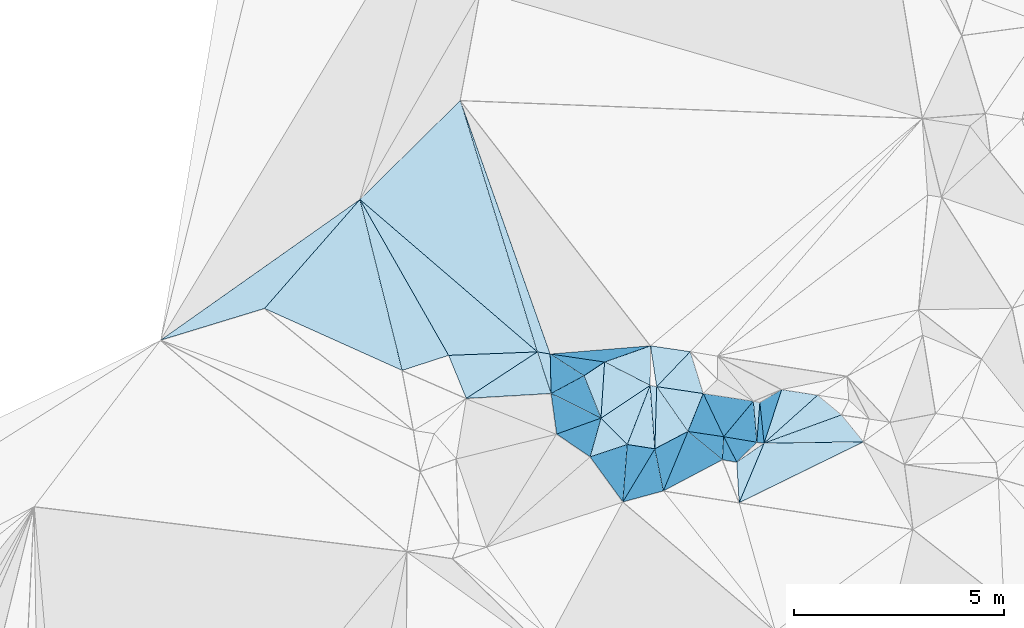
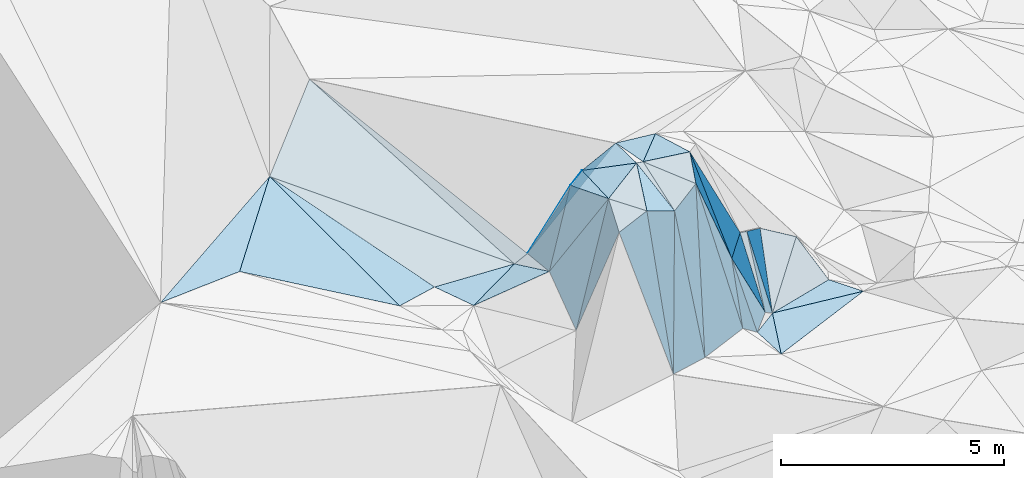
# One storey, part 123 of 275: 45 plates.
"""IFC2X3 building model written with IfcOpenShell, lengths in millimetres."""

from ifc_helpers import new_model, si_unit, frame, origin_with_axes, place, context, subcontext, project, spatial, polyline, outline, extrude, material, type_object, element, save


model = new_model("IFC2X3")

# Units and contexts
model_context = context("Model", 3, precision=1e-05, world=origin_with_axes())
body_context = subcontext(model_context, "Body", "Model", "MODEL_VIEW")
ifc_project = project(units=[si_unit("LENGTHUNIT", "METRE", prefix="MILLI"), si_unit("AREAUNIT", "SQUARE_METRE"), si_unit("VOLUMEUNIT", "CUBIC_METRE"), si_unit("MASSUNIT", "GRAM", prefix="KILO"), si_unit("TIMEUNIT", "SECOND"), si_unit("PLANEANGLEUNIT", "RADIAN"), si_unit("SOLIDANGLEUNIT", "STERADIAN"), si_unit("THERMODYNAMICTEMPERATUREUNIT", "DEGREE_CELSIUS"), si_unit("LUMINOUSINTENSITYUNIT", "LUMEN")], contexts=[model_context])

# Site, building, storey
site_placement = place(None, origin_with_axes())
site = spatial("IfcSite", under=ifc_project, at=site_placement, CompositionType="ELEMENT")
building_placement = place(site_placement, origin_with_axes())
building = spatial("IfcBuilding", under=site, at=building_placement, Name="Undefined", CompositionType="ELEMENT")
storey_placement = place(building_placement, origin_with_axes())
storey = spatial("IfcBuildingStorey", under=building, at=storey_placement, Name="Undefined", CompositionType="ELEMENT", Elevation=0.0)

# Plates
ifc_material = material()
plate_type_1 = type_object("IfcPlateType", PredefinedType="NOTDEFINED")
plate_1_placement = place(storey_placement, frame((-127172.939576721, 114067.120854425, 57145.5302917681), z_axis=(-0.0840497582433798, 0.33247181968247, -0.939360488447463), x_axis=(0.726799203152636, -0.624452343737679, -0.286045780771561)))
element("IfcPlate", 1, at=plate_1_placement, inside=storey, type_object=plate_type_1, material=ifc_material, Name="00", context=body_context, shape_type="SweptSolid", body=[
    extrude(outline(polyline([(0.0, 0.0), (5824.24267578125, -3.29109752783552e-08), (4291.6533203125, 1471.7578125), (0.0, 0.0)])), frame((-8.85201319254618e-08, 2.18876761149539e-07, -0.5000001331573), z_axis=(0.0, 0.0, 1.0), x_axis=(1.0, 0.0, 0.0)), (0.0, 0.0, 1.0), 1.0),
])
plate_type_2 = type_object("IfcPlateType", PredefinedType="NOTDEFINED")
plate_2_placement = place(storey_placement, frame((-121824.827324897, 109861.886820554, 57579.7868933312), z_axis=(0.524908520289815, -0.736789397555767, -0.426160097823067), x_axis=(-0.381293669960746, 0.244086897899004, -0.891648318297021)))
element("IfcPlate", 2, at=plate_2_placement, inside=storey, type_object=plate_type_2, material=ifc_material, Name="00", context=body_context, shape_type="SweptSolid", body=[
    extrude(outline(polyline([(0.0, 0.0), (2119.66967773438, -5.1804818212986e-09), (-142.946792602539, 572.333984375), (0.0, 0.0)])), frame((-8.85201319254618e-08, 2.18876761149539e-07, -0.5000001331573), z_axis=(0.0, 0.0, 1.0), x_axis=(1.0, 0.0, 0.0)), (0.0, 0.0, 1.0), 1.0),
])
plate_type_3 = type_object("IfcPlateType", PredefinedType="NOTDEFINED")
plate_3_placement = place(storey_placement, frame((-122939.799774544, 110429.87060153, 55479.5170197872), z_axis=(0.0858936731765158, -0.244234675615921, -0.965904601984602), x_axis=(0.304212956007485, -0.91675838155648, 0.258860092024883)))
element("IfcPlate", 3, at=plate_3_placement, inside=storey, type_object=plate_type_3, material=ifc_material, Name="00", context=body_context, shape_type="SweptSolid", body=[
    extrude(outline(polyline([(0.0, 0.0), (1081.66540527344, -5.55883161723614e-09), (535.840393066406, 1959.25366210938), (0.0, 0.0)])), frame((-8.85201319254618e-08, 2.18876761149539e-07, -0.5000001331573), z_axis=(0.0, 0.0, 1.0), x_axis=(1.0, 0.0, 0.0)), (0.0, 0.0, 1.0), 1.0),
])
plate_type_4 = type_object("IfcPlateType", PredefinedType="NOTDEFINED")
plate_4_placement = place(storey_placement, frame((-117628.94051765, 109224.930520439, 55239.748582044), z_axis=(-0.0955383613260022, 0.859116325632494, -0.502783810943496), x_axis=(0.0523056062937232, -0.500063738080834, -0.864407532016507)))
element("IfcPlate", 4, at=plate_4_placement, inside=storey, type_object=plate_type_4, material=ifc_material, Name="00", context=body_context, shape_type="SweptSolid", body=[
    extrude(outline(polyline([(0.0, 0.0), (1943.52770996094, -7.40692485123873e-09), (1863.10693359375, 170.389251708984), (0.0, 0.0)])), frame((-8.85201319254618e-08, 2.18876761149539e-07, -0.5000001331573), z_axis=(0.0, 0.0, 1.0), x_axis=(1.0, 0.0, 0.0)), (0.0, 0.0, 1.0), 1.0),
])
plate_type_5 = type_object("IfcPlateType", PredefinedType="NOTDEFINED")
plate_5_placement = place(storey_placement, frame((-121334.99427368, 110188.205598144, 57619.5041985265), z_axis=(0.115421488089065, -0.0592361526261697, -0.991548767489202), x_axis=(0.882497580006892, -0.452069672772387, 0.1297344682089)))
element("IfcPlate", 5, at=plate_5_placement, inside=storey, type_object=plate_type_5, material=ifc_material, Name="00", context=body_context, shape_type="SweptSolid", body=[
    extrude(outline(polyline([(0.0, 0.0), (1233.28833007813, 8.25821189209819e-09), (538.641296386719, 1230.96118164063), (0.0, 0.0)])), frame((-8.85201319254618e-08, 2.18876761149539e-07, -0.5000001331573), z_axis=(0.0, 0.0, 1.0), x_axis=(1.0, 0.0, 0.0)), (0.0, 0.0, 1.0), 1.0),
])
plate_type_6 = type_object("IfcPlateType", PredefinedType="NOTDEFINED")
plate_6_placement = place(storey_placement, frame((-117527.288152102, 108252.652764839, 53559.5043438252), z_axis=(-0.105598940437367, 0.0790763816793108, -0.991259698383332), x_axis=(0.994398388491212, 0.0129590261855554, -0.104899516711961)))
element("IfcPlate", 6, at=plate_6_placement, inside=storey, type_object=plate_type_6, material=ifc_material, Name="00", context=body_context, shape_type="SweptSolid", body=[
    extrude(outline(polyline([(0.0, 0.0), (2383.23315429688, -1.12486304715276e-08), (-605.605895996094, 1419.06359863281), (0.0, 0.0)])), frame((-8.85201319254618e-08, 2.18876761149539e-07, -0.5000001331573), z_axis=(0.0, 0.0, 1.0), x_axis=(1.0, 0.0, 0.0)), (0.0, 0.0, 1.0), 1.0),
])
plate_type_7 = type_object("IfcPlateType", PredefinedType="NOTDEFINED")
plate_7_placement = place(storey_placement, frame((-120246.61358742, 109630.686629709, 57779.5044175174), z_axis=(0.128944405817825, -0.0327123870062438, -0.991112122791686), x_axis=(-0.882497580034507, 0.452069672719858, -0.129734468204099)))
element("IfcPlate", 7, at=plate_7_placement, inside=storey, type_object=plate_type_7, material=ifc_material, Name="00", context=body_context, shape_type="SweptSolid", body=[
    extrude(outline(polyline([(0.0, 0.0), (1233.28833007813, 8.25821189209819e-09), (422.853271484375, 844.863952636719), (0.0, 0.0)])), frame((-8.85201319254618e-08, 2.18876761149539e-07, -0.5000001331573), z_axis=(0.0, 0.0, 1.0), x_axis=(1.0, 0.0, 0.0)), (0.0, 0.0, 1.0), 1.0),
])
plate_type_8 = type_object("IfcPlateType", PredefinedType="NOTDEFINED")
plate_8_placement = place(storey_placement, frame((-120897.87211962, 106850.39406383, 53919.8217663494), z_axis=(0.0537045561599586, 0.932782810628323, -0.356415556400092), x_axis=(0.027312584689679, 0.355424939972838, 0.934305696634069)))
element("IfcPlate", 8, at=plate_8_placement, inside=storey, type_object=plate_type_8, material=ifc_material, Name="00", context=body_context, shape_type="SweptSolid", body=[
    extrude(outline(polyline([(0.0, 0.0), (3853.12866210938, 1.67638063430786e-08), (3675.71435546875, 663.795288085938), (0.0, 0.0)])), frame((-8.85201319254618e-08, 2.18876761149539e-07, -0.5000001331573), z_axis=(0.0, 0.0, 1.0), x_axis=(1.0, 0.0, 0.0)), (0.0, 0.0, 1.0), 1.0),
])
plate_type_9 = type_object("IfcPlateType", PredefinedType="NOTDEFINED")
plate_9_placement = place(storey_placement, frame((-118980.327690746, 109436.521387115, 57759.8296986031), z_axis=(-0.844897435322132, 0.412521827392873, -0.340549652342399), x_axis=(0.180119604287837, -0.380059422050479, -0.907255071003656)))
element("IfcPlate", 9, at=plate_9_placement, inside=storey, type_object=plate_type_9, material=ifc_material, Name="00", context=body_context, shape_type="SweptSolid", body=[
    extrude(outline(polyline([(0.0, 0.0), (2711.4755859375, -1.08011590782553e-08), (450.529602050781, 886.297424316406), (0.0, 0.0)])), frame((-8.85201319254618e-08, 2.18876761149539e-07, -0.5000001331573), z_axis=(0.0, 0.0, 1.0), x_axis=(1.0, 0.0, 0.0)), (0.0, 0.0, 1.0), 1.0),
])
plate_type_10 = type_object("IfcPlateType", PredefinedType="NOTDEFINED")
plate_10_placement = place(storey_placement, frame((-121679.167779488, 107925.614703113, 57419.8460653225), z_axis=(0.93574440796713, -0.172138843323669, -0.307815889091895), x_axis=(-0.275579687908912, 0.187779193895734, -0.942759147371106)))
element("IfcPlate", 10, at=plate_10_placement, inside=storey, type_object=plate_type_10, material=ifc_material, Name="00", context=body_context, shape_type="SweptSolid", body=[
    extrude(outline(polyline([(0.0, 0.0), (2895.75561523438, -4.08908817917109e-09), (-152.429992675781, 984.563415527344), (0.0, 0.0)])), frame((-8.85201319254618e-08, 2.18876761149539e-07, -0.5000001331573), z_axis=(0.0, 0.0, 1.0), x_axis=(1.0, 0.0, 0.0)), (0.0, 0.0, 1.0), 1.0),
])
plate_type_11 = type_object("IfcPlateType", PredefinedType="NOTDEFINED")
plate_11_placement = place(storey_placement, frame((-119345.170555473, 108531.442127853, 57569.5101914301), z_axis=(0.0121128882629374, 0.200771134037029, -0.979563285181419), x_axis=(-0.564890506441915, 0.80970766923569, 0.158972343861135)))
element("IfcPlate", 11, at=plate_11_placement, inside=storey, type_object=plate_type_11, material=ifc_material, Name="00", context=body_context, shape_type="SweptSolid", body=[
    extrude(outline(polyline([(0.0, 0.0), (1320.98449707031, -3.18686943501234e-09), (556.630310058594, 823.809875488281), (0.0, 0.0)])), frame((-8.85201319254618e-08, 2.18876761149539e-07, -0.5000001331573), z_axis=(0.0, 0.0, 1.0), x_axis=(1.0, 0.0, 0.0)), (0.0, 0.0, 1.0), 1.0),
])
plate_type_12 = type_object("IfcPlateType", PredefinedType="NOTDEFINED")
plate_12_placement = place(storey_placement, frame((-118491.876481331, 108406.080765571, 55299.8078385976), z_axis=(-0.722304831567893, 0.574988767741143, -0.384270278925133), x_axis=(-0.18011960428778, 0.380059422051083, 0.907255071003414)))
element("IfcPlate", 12, at=plate_12_placement, inside=storey, type_object=plate_type_12, material=ifc_material, Name="00", context=body_context, shape_type="SweptSolid", body=[
    extrude(outline(polyline([(0.0, 0.0), (2711.4755859375, -1.08011590782553e-08), (140.624542236328, 1097.28063964844), (0.0, 0.0)])), frame((-8.85201319254618e-08, 2.18876761149539e-07, -0.5000001331573), z_axis=(0.0, 0.0, 1.0), x_axis=(1.0, 0.0, 0.0)), (0.0, 0.0, 1.0), 1.0),
])
plate_type_13 = type_object("IfcPlateType", PredefinedType="NOTDEFINED")
plate_13_placement = place(storey_placement, frame((-118491.827664675, 108406.142124906, 55299.8246190274), z_axis=(-0.624669649436294, 0.697703847341124, -0.350709524362444), x_axis=(0.426849675085208, -0.0709979859672468, -0.901531275590729)))
element("IfcPlate", 13, at=plate_13_placement, inside=storey, type_object=plate_type_13, material=ifc_material, Name="00", context=body_context, shape_type="SweptSolid", body=[
    extrude(outline(polyline([(0.0, 0.0), (1852.40380859375, 2.66300048679113e-09), (1762.6826171875, 674.203308105469), (0.0, 0.0)])), frame((-8.85201319254618e-08, 2.18876761149539e-07, -0.5000001331573), z_axis=(0.0, 0.0, 1.0), x_axis=(1.0, 0.0, 0.0)), (0.0, 0.0, 1.0), 1.0),
])
plate_type_14 = type_object("IfcPlateType", PredefinedType="NOTDEFINED")
plate_14_placement = place(storey_placement, frame((-122610.506540229, 109438.342825378, 55759.5861274751), z_axis=(0.559114686730362, -0.048176092364468, -0.827689453362129), x_axis=(-0.304212956009918, 0.916758381555947, -0.258860092023912)))
element("IfcPlate", 14, at=plate_14_placement, inside=storey, type_object=plate_type_14, material=ifc_material, Name="00", context=body_context, shape_type="SweptSolid", body=[
    extrude(outline(polyline([(0.0, 0.0), (1081.66540527344, -5.55883161723614e-09), (887.89013671875, 321.015808105469), (0.0, 0.0)])), frame((-8.85201319254618e-08, 2.18876761149539e-07, -0.5000001331573), z_axis=(0.0, 0.0, 1.0), x_axis=(1.0, 0.0, 0.0)), (0.0, 0.0, 1.0), 1.0),
])
plate_type_15 = type_object("IfcPlateType", PredefinedType="NOTDEFINED")
plate_15_placement = place(storey_placement, frame((-118179.990980498, 107800.506008044, 53539.8351636943), z_axis=(-0.0271668666170141, 0.943722571189827, -0.32962049387906), x_axis=(-0.865215973139182, 0.142951842845666, 0.480589315790361)))
element("IfcPlate", 15, at=plate_15_placement, inside=storey, type_object=plate_type_15, material=ifc_material, Name="00", context=body_context, shape_type="SweptSolid", body=[
    extrude(outline(polyline([(0.0, 0.0), (395.347961425781, 1.26601662486792e-09), (1201.97912597656, 1454.9384765625), (0.0, 0.0)])), frame((-8.85201319254618e-08, 2.18876761149539e-07, -0.5000001331573), z_axis=(0.0, 0.0, 1.0), x_axis=(1.0, 0.0, 0.0)), (0.0, 0.0, 1.0), 1.0),
])
plate_type_16 = type_object("IfcPlateType", PredefinedType="NOTDEFINED")
plate_16_placement = place(storey_placement, frame((-117700.736257544, 108274.699632797, 53629.7465176876), z_axis=(0.162189568164845, 0.846602149252938, -0.506911574989965), x_axis=(-0.0441872193018238, 0.519429277936636, 0.853370209740531)))
element("IfcPlate", 16, at=plate_16_placement, inside=storey, type_object=plate_type_16, material=ifc_material, Name="00", context=body_context, shape_type="SweptSolid", body=[
    extrude(outline(polyline([(0.0, 0.0), (1886.63720703125, -2.43016984313726e-09), (1864.32238769531, 156.531295776367), (0.0, 0.0)])), frame((-8.85201319254618e-08, 2.18876761149539e-07, -0.5000001331573), z_axis=(0.0, 0.0, 1.0), x_axis=(1.0, 0.0, 0.0)), (0.0, 0.0, 1.0), 1.0),
])
plate_type_17 = type_object("IfcPlateType", PredefinedType="NOTDEFINED")
plate_17_placement = place(storey_placement, frame((-117527.544266772, 108252.945153256, 53559.7892620882), z_axis=(-0.617825198170424, 0.663847842602728, -0.421423855966152), x_axis=(-0.0523056063160503, 0.500063738071532, 0.864407532020538)))
element("IfcPlate", 17, at=plate_17_placement, inside=storey, type_object=plate_type_17, material=ifc_material, Name="00", context=body_context, shape_type="SweptSolid", body=[
    extrude(outline(polyline([(0.0, 0.0), (1943.52770996094, -7.40692485123873e-09), (1827.6044921875, 655.638488769531), (0.0, 0.0)])), frame((-8.85201319254618e-08, 2.18876761149539e-07, -0.5000001331573), z_axis=(0.0, 0.0, 1.0), x_axis=(1.0, 0.0, 0.0)), (0.0, 0.0, 1.0), 1.0),
])
plate_type_18 = type_object("IfcPlateType", PredefinedType="NOTDEFINED")
plate_18_placement = place(storey_placement, frame((-121420.513873093, 108849.30583105, 57689.7821673213), z_axis=(0.851345107254935, 0.292325930784554, -0.435611132254478), x_axis=(-0.507915912830475, 0.251517924810495, -0.823869018104582)))
element("IfcPlate", 18, at=plate_18_placement, inside=storey, type_object=plate_type_18, material=ifc_material, Name="00", context=body_context, shape_type="SweptSolid", body=[
    extrude(outline(polyline([(0.0, 0.0), (2342.60546875, -4.51109372079372e-09), (550.711608886719, 947.901245117188), (0.0, 0.0)])), frame((-8.85201319254618e-08, 2.18876761149539e-07, -0.5000001331573), z_axis=(0.0, 0.0, 1.0), x_axis=(1.0, 0.0, 0.0)), (0.0, 0.0, 1.0), 1.0),
])
plate_type_19 = type_object("IfcPlateType", PredefinedType="NOTDEFINED")
plate_19_placement = place(storey_placement, frame((-120898.029786903, 106850.379979577, 53919.8317329329), z_axis=(-0.261630540679101, 0.904615539903942, -0.336482072551067), x_axis=(-0.208790755328857, 0.287323704111256, 0.934800251147267)))
element("IfcPlate", 19, at=plate_19_placement, inside=storey, type_object=plate_type_19, material=ifc_material, Name="00", context=body_context, shape_type="SweptSolid", body=[
    extrude(outline(polyline([(0.0, 0.0), (3744.11547851563, -9.61881596595049e-09), (3736.79711914063, 939.652282714844), (0.0, 0.0)])), frame((-8.85201319254618e-08, 2.18876761149539e-07, -0.5000001331573), z_axis=(0.0, 0.0, 1.0), x_axis=(1.0, 0.0, 0.0)), (0.0, 0.0, 1.0), 1.0),
])
plate_type_20 = type_object("IfcPlateType", PredefinedType="NOTDEFINED")
plate_20_placement = place(storey_placement, frame((-127173.033219942, 114067.112502623, 57145.5453522989), z_axis=(-0.271195394198383, 0.315783845944614, -0.909248932254535), x_axis=(-0.65741873450322, -0.750746778201665, -0.0646520111365831)))
element("IfcPlate", 20, at=plate_20_placement, inside=storey, type_object=plate_type_20, material=ifc_material, Name="00", context=body_context, shape_type="SweptSolid", body=[
    extrude(outline(polyline([(0.0, 0.0), (3464.70263671875, -2.4476321414113e-08), (5632.046875, 1500.78125), (0.0, 0.0)])), frame((-8.85201319254618e-08, 2.18876761149539e-07, -0.5000001331573), z_axis=(0.0, 0.0, 1.0), x_axis=(1.0, 0.0, 0.0)), (0.0, 0.0, 1.0), 1.0),
])
plate_type_21 = type_object("IfcPlateType", PredefinedType="NOTDEFINED")
plate_21_placement = place(storey_placement, frame((-118122.986745631, 106830.280527921, 53509.5002406356), z_axis=(0.00882652118324734, 0.0314373645567734, -0.999466750139056), x_axis=(-0.0586335262089239, 0.997802247637457, 0.0308672028850613)))
element("IfcPlate", 21, at=plate_21_placement, inside=storey, type_object=plate_type_21, material=ifc_material, Name="00", context=body_context, shape_type="SweptSolid", body=[
    extrude(outline(polyline([(0.0, 0.0), (971.905334472656, 1.26601662486792e-09), (1385.83459472656, 678.205444335938), (0.0, 0.0)])), frame((-8.85201319254618e-08, 2.18876761149539e-07, -0.5000001331573), z_axis=(0.0, 0.0, 1.0), x_axis=(1.0, 0.0, 0.0)), (0.0, 0.0, 1.0), 1.0),
])
plate_type_22 = type_object("IfcPlateType", PredefinedType="NOTDEFINED")
plate_22_placement = place(storey_placement, frame((-120246.651579788, 109630.841197185, 57779.520185483), z_axis=(0.0529566791147433, 0.276424918776054, -0.95957535108859), x_axis=(0.98213927472563, -0.188155374734322, 2.49505239104413e-10)))
element("IfcPlate", 22, at=plate_22_placement, inside=storey, type_object=plate_type_22, material=ifc_material, Name="00", context=body_context, shape_type="SweptSolid", body=[
    extrude(outline(polyline([(0.0, 0.0), (158.113876342773, 6.40284270048141e-10), (394.652252197266, 1527.79235839844), (0.0, 0.0)])), frame((-8.85201319254618e-08, 2.18876761149539e-07, -0.5000001331573), z_axis=(0.0, 0.0, 1.0), x_axis=(1.0, 0.0, 0.0)), (0.0, 0.0, 1.0), 1.0),
])
plate_type_23 = type_object("IfcPlateType", PredefinedType="NOTDEFINED")
plate_23_placement = place(storey_placement, frame((-124635.661299559, 109319.484283303, 55609.5013918202), z_axis=(-0.0752889469623513, -0.00176249610350033, -0.997160201809511), x_axis=(-0.379347486268862, 0.924860038109411, 0.0270073058588546)))
element("IfcPlate", 23, at=plate_23_placement, inside=storey, type_object=plate_type_23, material=ifc_material, Name="00", context=body_context, shape_type="SweptSolid", body=[
    extrude(outline(polyline([(0.0, 0.0), (1110.810546875, 3.49245965480804e-10), (380.262878417969, 1995.29455566406), (0.0, 0.0)])), frame((-8.85201319254618e-08, 2.18876761149539e-07, -0.5000001331573), z_axis=(0.0, 0.0, 1.0), x_axis=(1.0, 0.0, 0.0)), (0.0, 0.0, 1.0), 1.0),
])
plate_type_24 = type_object("IfcPlateType", PredefinedType="NOTDEFINED")
plate_24_placement = place(storey_placement, frame((-127172.982069396, 114067.097475043, 57145.5283278775), z_axis=(-0.169045525666872, 0.2857180981798, -0.943286159457738), x_axis=(0.4663634840826, -0.819952814637612, -0.331937467728782)))
element("IfcPlate", 24, at=plate_24_placement, inside=storey, type_object=plate_type_24, material=ifc_material, Name="00", context=body_context, shape_type="SweptSolid", body=[
    extrude(outline(polyline([(0.0, 0.0), (4536.9990234375, 9.50240064412355e-09), (4284.30810546875, 1142.03637695313), (0.0, 0.0)])), frame((-8.85201319254618e-08, 2.18876761149539e-07, -0.5000001331573), z_axis=(0.0, 0.0, 1.0), x_axis=(1.0, 0.0, 0.0)), (0.0, 0.0, 1.0), 1.0),
])
plate_type_25 = type_object("IfcPlateType", PredefinedType="NOTDEFINED")
plate_25_placement = place(storey_placement, frame((-119931.978891423, 107113.476902548, 53879.8614080152), z_axis=(-0.385092214900645, 0.88028533360275, -0.277131227880963), x_axis=(-0.0561456222692682, 0.277387139984796, 0.959116282663918)))
element("IfcPlate", 25, at=plate_25_placement, inside=storey, type_object=plate_type_25, material=ifc_material, Name="00", context=body_context, shape_type="SweptSolid", body=[
    extrude(outline(polyline([(0.0, 0.0), (3617.91381835938, 2.7648638933897e-09), (3899.623046875, 874.494079589844), (0.0, 0.0)])), frame((-8.85201319254618e-08, 2.18876761149539e-07, -0.5000001331573), z_axis=(0.0, 0.0, 1.0), x_axis=(1.0, 0.0, 0.0)), (0.0, 0.0, 1.0), 1.0),
])
plate_type_26 = type_object("IfcPlateType", PredefinedType="NOTDEFINED")
plate_26_placement = place(storey_placement, frame((-122632.847097498, 110379.635142241, 55689.8025301049), z_axis=(0.918701210940845, -0.00738619714177169, -0.394884197085181), x_axis=(0.381293669948601, -0.244086897913359, 0.891648318298286)))
element("IfcPlate", 26, at=plate_26_placement, inside=storey, type_object=plate_type_26, material=ifc_material, Name="00", context=body_context, shape_type="SweptSolid", body=[
    extrude(outline(polyline([(0.0, 0.0), (2119.66967773438, -5.1804818212986e-09), (300.75439453125, 894.956298828125), (0.0, 0.0)])), frame((-8.85201319254618e-08, 2.18876761149539e-07, -0.5000001331573), z_axis=(0.0, 0.0, 1.0), x_axis=(1.0, 0.0, 0.0)), (0.0, 0.0, 1.0), 1.0),
])
plate_type_27 = type_object("IfcPlateType", PredefinedType="NOTDEFINED")
plate_27_placement = place(storey_placement, frame((-121420.931114561, 108849.297785369, 57689.5195016228), z_axis=(0.0168629320107411, 0.276235345573662, -0.960942077015988), x_axis=(0.693734016416023, -0.695340065099752, -0.187710703835357)))
element("IfcPlate", 27, at=plate_27_placement, inside=storey, type_object=plate_type_27, material=ifc_material, Name="00", context=body_context, shape_type="SweptSolid", body=[
    extrude(outline(polyline([(0.0, 0.0), (905.64892578125, -3.01042746286839e-10), (513.333557128906, 853.866882324219), (0.0, 0.0)])), frame((-8.85201319254618e-08, 2.18876761149539e-07, -0.5000001331573), z_axis=(0.0, 0.0, 1.0), x_axis=(1.0, 0.0, 0.0)), (0.0, 0.0, 1.0), 1.0),
])
plate_type_28 = type_object("IfcPlateType", PredefinedType="NOTDEFINED")
plate_28_placement = place(storey_placement, frame((-121420.87934395, 108849.129887931, 57689.504506205), z_axis=(0.120485103570991, -0.0595285161849457, -0.990928703579781), x_axis=(-0.368660607691914, 0.924132634058661, -0.100340575063277)))
element("IfcPlate", 28, at=plate_28_placement, inside=storey, type_object=plate_type_28, material=ifc_material, Name="00", context=body_context, shape_type="SweptSolid", body=[
    extrude(outline(polyline([(0.0, 0.0), (1096.26635742188, -6.11180439591408e-10), (1212.84387207031, 578.281677246094), (0.0, 0.0)])), frame((-8.85201319254618e-08, 2.18876761149539e-07, -0.5000001331573), z_axis=(0.0, 0.0, 1.0), x_axis=(1.0, 0.0, 0.0)), (0.0, 0.0, 1.0), 1.0),
])
plate_type_29 = type_object("IfcPlateType", PredefinedType="NOTDEFINED")
plate_29_placement = place(storey_placement, frame((-120135.018738341, 108116.726206415, 57349.527249726), z_axis=(-0.204746860743059, 0.253390721992916, -0.945447970553521), x_axis=(-0.957281573746786, 0.149653415765696, 0.247418357674885)))
element("IfcPlate", 29, at=plate_29_placement, inside=storey, type_object=plate_type_29, material=ifc_material, Name="00", context=body_context, shape_type="SweptSolid", body=[
    extrude(outline(polyline([(0.0, 0.0), (687.095336914063, -3.20142135024071e-10), (439.968048095703, 1515.36401367188), (0.0, 0.0)])), frame((-8.85201319254618e-08, 2.18876761149539e-07, -0.5000001331573), z_axis=(0.0, 0.0, 1.0), x_axis=(1.0, 0.0, 0.0)), (0.0, 0.0, 1.0), 1.0),
])
plate_type_30 = type_object("IfcPlateType", PredefinedType="NOTDEFINED")
plate_30_placement = place(storey_placement, frame((-120091.326933694, 109601.089424565, 57779.5228602425), z_axis=(0.122538489534479, 0.272834561317049, -0.954225141532931), x_axis=(0.564890506439869, -0.809707669237286, -0.158972343860279)))
element("IfcPlate", 30, at=plate_30_placement, inside=storey, type_object=plate_type_30, material=ifc_material, Name="00", context=body_context, shape_type="SweptSolid", body=[
    extrude(outline(polyline([(0.0, 0.0), (1320.98449707031, -3.18686943501234e-09), (1245.66186523438, 915.656311035156), (0.0, 0.0)])), frame((-8.85201319254618e-08, 2.18876761149539e-07, -0.5000001331573), z_axis=(0.0, 0.0, 1.0), x_axis=(1.0, 0.0, 0.0)), (0.0, 0.0, 1.0), 1.0),
])
plate_type_31 = type_object("IfcPlateType", PredefinedType="NOTDEFINED")
plate_31_placement = place(storey_placement, frame((-115682.093459803, 108926.269426303, 53419.5045216598), z_axis=(-0.105617558402447, 0.0833683392769735, -0.990905975036635), x_axis=(0.626898796118236, -0.767935233761579, -0.131428216806952)))
element("IfcPlate", 31, at=plate_31_placement, inside=storey, type_object=plate_type_31, material=ifc_material, Name="00", context=body_context, shape_type="SweptSolid", body=[
    extrude(outline(polyline([(0.0, 0.0), (836.958801269531, -1.83717929758132e-09), (-657.857971191406, 1856.15808105469), (0.0, 0.0)])), frame((-8.85201319254618e-08, 2.18876761149539e-07, -0.5000001331573), z_axis=(0.0, 0.0, 1.0), x_axis=(1.0, 0.0, 0.0)), (0.0, 0.0, 1.0), 1.0),
])
plate_type_32 = type_object("IfcPlateType", PredefinedType="NOTDEFINED")
plate_32_placement = place(storey_placement, frame((-120135.047839034, 108117.060812919, 57349.858862737), z_axis=(-0.262946616898163, 0.922610379890672, -0.282221833988445), x_axis=(0.0561456232676465, -0.277387139979887, -0.959116282606893)))
element("IfcPlate", 32, at=plate_32_placement, inside=storey, type_object=plate_type_32, material=ifc_material, Name="00", context=body_context, shape_type="SweptSolid", body=[
    extrude(outline(polyline([(0.0, 0.0), (3617.91381835938, 2.7648638933897e-09), (3598.28930664063, 1001.90563964844), (0.0, 0.0)])), frame((-8.85201319254618e-08, 2.18876761149539e-07, -0.5000001331573), z_axis=(0.0, 0.0, 1.0), x_axis=(1.0, 0.0, 0.0)), (0.0, 0.0, 1.0), 1.0),
])
plate_type_33 = type_object("IfcPlateType", PredefinedType="NOTDEFINED")
plate_33_placement = place(storey_placement, frame((-119345.412796732, 108531.764370384, 57569.8750770541), z_axis=(-0.472375927717699, 0.845259986970018, -0.249792988973446), x_axis=(0.206570279218049, -0.169342165003141, -0.963665891736252)))
element("IfcPlate", 33, at=plate_33_placement, inside=storey, type_object=plate_type_33, material=ifc_material, Name="00", context=body_context, shape_type="SweptSolid", body=[
    extrude(outline(polyline([(0.0, 0.0), (3984.78344726563, -7.21774995326996e-09), (3674.92993164063, 1570.57019042969), (0.0, 0.0)])), frame((-8.85201319254618e-08, 2.18876761149539e-07, -0.5000001331573), z_axis=(0.0, 0.0, 1.0), x_axis=(1.0, 0.0, 0.0)), (0.0, 0.0, 1.0), 1.0),
])
plate_type_34 = type_object("IfcPlateType", PredefinedType="NOTDEFINED")
plate_34_placement = place(storey_placement, frame((-119345.464997183, 108531.728996822, 57569.8701039169), z_axis=(-0.576773172918046, 0.774511668598551, -0.259739065615358), x_axis=(0.351524250324383, -0.051698879022025, -0.934750195154698)))
element("IfcPlate", 34, at=plate_34_placement, inside=storey, type_object=plate_type_34, material=ifc_material, Name="00", context=body_context, shape_type="SweptSolid", body=[
    extrude(outline(polyline([(0.0, 0.0), (2428.45629882813, -9.06948116607964e-09), (3913.6796875, 749.407470703125), (0.0, 0.0)])), frame((-8.85201319254618e-08, 2.18876761149539e-07, -0.5000001331573), z_axis=(0.0, 0.0, 1.0), x_axis=(1.0, 0.0, 0.0)), (0.0, 0.0, 1.0), 1.0),
])
plate_type_35 = type_object("IfcPlateType", PredefinedType="NOTDEFINED")
plate_35_placement = place(storey_placement, frame((-120792.690322148, 108219.527395486, 57519.5113650662), z_axis=(-0.0605042542631268, 0.203440121107466, -0.977216123659369), x_axis=(-0.693734016420507, 0.695340065094498, 0.187710703838248)))
element("IfcPlate", 35, at=plate_35_placement, inside=storey, type_object=plate_type_35, material=ifc_material, Name="00", context=body_context, shape_type="SweptSolid", body=[
    extrude(outline(polyline([(0.0, 0.0), (905.64892578125, -3.01042746286839e-10), (651.356140136719, 1390.37231445313), (0.0, 0.0)])), frame((-8.85201319254618e-08, 2.18876761149539e-07, -0.5000001331573), z_axis=(0.0, 0.0, 1.0), x_axis=(1.0, 0.0, 0.0)), (0.0, 0.0, 1.0), 1.0),
])
plate_type_36 = type_object("IfcPlateType", PredefinedType="NOTDEFINED")
plate_36_placement = place(storey_placement, frame((-126166.58135492, 109987.679509343, 55729.5312713451), z_axis=(-0.21797486112372, 0.271603618599857, -0.93739982626495), x_axis=(-0.865696411001612, 0.389672235775914, 0.314205780730287)))
element("IfcPlate", 36, at=plate_36_placement, inside=storey, type_object=plate_type_36, material=ifc_material, Name="00", context=body_context, shape_type="SweptSolid", body=[
    extrude(outline(polyline([(0.0, 0.0), (3793.69213867188, 1.04118953458965e-08), (2905.80712890625, 3349.00366210938), (0.0, 0.0)])), frame((-8.85201319254618e-08, 2.18876761149539e-07, -0.5000001331573), z_axis=(0.0, 0.0, 1.0), x_axis=(1.0, 0.0, 0.0)), (0.0, 0.0, 1.0), 1.0),
])
plate_type_37 = type_object("IfcPlateType", PredefinedType="NOTDEFINED")
plate_37_placement = place(storey_placement, frame((-122610.3856591, 109438.61195277, 55759.8279104886), z_axis=(0.800874658965999, 0.490080085888609, -0.3441239457543), x_axis=(0.507915912853347, -0.25151792482649, 0.823869018085598)))
element("IfcPlate", 37, at=plate_37_placement, inside=storey, type_object=plate_type_37, material=ifc_material, Name="00", context=body_context, shape_type="SweptSolid", body=[
    extrude(outline(polyline([(0.0, 0.0), (2342.60546875, -4.51109372079372e-09), (-570.219787597656, 1332.76000976563), (0.0, 0.0)])), frame((-8.85201319254618e-08, 2.18876761149539e-07, -0.5000001331573), z_axis=(0.0, 0.0, 1.0), x_axis=(1.0, 0.0, 0.0)), (0.0, 0.0, 1.0), 1.0),
])
plate_type_38 = type_object("IfcPlateType", PredefinedType="NOTDEFINED")
plate_38_placement = place(storey_placement, frame((-120091.385115019, 109600.938075908, 57779.5002059562), z_axis=(0.00617396138255496, -0.0298587699722715, -0.999535059943667), x_axis=(-0.148497611169171, 0.988444019637501, -0.030444696088298)))
element("IfcPlate", 38, at=plate_38_placement, inside=storey, type_object=plate_type_38, material=ifc_material, Name="00", context=body_context, shape_type="SweptSolid", body=[
    extrude(outline(polyline([(0.0, 0.0), (985.393310546875, -4.55474946647882e-09), (707.128784179688, 915.897827148438), (0.0, 0.0)])), frame((-8.85201319254618e-08, 2.18876761149539e-07, -0.5000001331573), z_axis=(0.0, 0.0, 1.0), x_axis=(1.0, 0.0, 0.0)), (0.0, 0.0, 1.0), 1.0),
])
plate_type_39 = type_object("IfcPlateType", PredefinedType="NOTDEFINED")
plate_39_placement = place(storey_placement, frame((-117784.543384388, 109254.538033023, 55239.8065453325), z_axis=(-0.721561650364777, 0.57418621928174, -0.386857816658524), x_axis=(0.0441872192826112, -0.519429277922755, -0.853370209749975)))
element("IfcPlate", 39, at=plate_39_placement, inside=storey, type_object=plate_type_39, material=ifc_material, Name="00", context=body_context, shape_type="SweptSolid", body=[
    extrude(outline(polyline([(0.0, 0.0), (1886.63720703125, -2.43016984313726e-09), (358.256469726563, 1046.63854980469), (0.0, 0.0)])), frame((-8.85201319254618e-08, 2.18876761149539e-07, -0.5000001331573), z_axis=(0.0, 0.0, 1.0), x_axis=(1.0, 0.0, 0.0)), (0.0, 0.0, 1.0), 1.0),
])
plate_type_40 = type_object("IfcPlateType", PredefinedType="NOTDEFINED")
plate_40_placement = place(storey_placement, frame((-117108.537241963, 109531.505837398, 54959.6877364753), z_axis=(-0.209472949430475, 0.752430022960593, -0.624475895455076), x_axis=(0.877083054723183, -0.137737727759395, -0.460166962600672)))
element("IfcPlate", 40, at=plate_40_placement, inside=storey, type_object=plate_type_40, material=ifc_material, Name="00", context=body_context, shape_type="SweptSolid", body=[
    extrude(outline(polyline([(0.0, 0.0), (977.905944824219, -1.02591002359986e-09), (453.008819580078, 1888.06335449219), (0.0, 0.0)])), frame((-8.85201319254618e-08, 2.18876761149539e-07, -0.5000001331573), z_axis=(0.0, 0.0, 1.0), x_axis=(1.0, 0.0, 0.0)), (0.0, 0.0, 1.0), 1.0),
])
plate_type_41 = type_object("IfcPlateType", PredefinedType="NOTDEFINED")
plate_41_placement = place(storey_placement, frame((-116250.891987725, 109396.831513198, 54509.743295275), z_axis=(-0.328393404593389, 0.792856532633662, -0.513357858106496), x_axis=(0.43204029024791, -0.357223686911049, -0.828089623840426)))
element("IfcPlate", 41, at=plate_41_placement, inside=storey, type_object=plate_type_41, material=ifc_material, Name="00", context=body_context, shape_type="SweptSolid", body=[
    extrude(outline(polyline([(0.0, 0.0), (1316.28259277344, -4.93309926241636e-09), (643.78271484375, 1850.90356445313), (0.0, 0.0)])), frame((-8.85201319254618e-08, 2.18876761149539e-07, -0.5000001331573), z_axis=(0.0, 0.0, 1.0), x_axis=(1.0, 0.0, 0.0)), (0.0, 0.0, 1.0), 1.0),
])
plate_type_42 = type_object("IfcPlateType", PredefinedType="NOTDEFINED")
plate_42_placement = place(storey_placement, frame((-121334.877793328, 110187.795003119, 57619.8391402296), z_axis=(0.348389166689807, -0.880429463626997, -0.321665895162451), x_axis=(-0.556264233861112, 0.0820108778028471, -0.82694880013754)))
element("IfcPlate", 42, at=plate_42_placement, inside=storey, type_object=plate_type_42, material=ifc_material, Name="00", context=body_context, shape_type="SweptSolid", body=[
    extrude(outline(polyline([(0.0, 0.0), (2333.880859375, -8.76025296747684e-09), (-686.196105957031, 948.543579101563), (0.0, 0.0)])), frame((-8.85201319254618e-08, 2.18876761149539e-07, -0.5000001331573), z_axis=(0.0, 0.0, 1.0), x_axis=(1.0, 0.0, 0.0)), (0.0, 0.0, 1.0), 1.0),
])
plate_type_43 = type_object("IfcPlateType", PredefinedType="NOTDEFINED")
plate_43_placement = place(storey_placement, frame((-122633.026799993, 110379.847368402, 55689.6417684138), z_axis=(0.559302608798113, 0.4170585814617, -0.716409611479898), x_axis=(-0.817502731029316, 0.1342889567577, -0.560049784262559)))
element("IfcPlate", 43, at=plate_43_placement, inside=storey, type_object=plate_type_43, material=ifc_material, Name="00", context=body_context, shape_type="SweptSolid", body=[
    extrude(outline(polyline([(0.0, 0.0), (374.966674804688, 2.91038304567337e-10), (1530.77612304688, 6502.2958984375), (0.0, 0.0)])), frame((-8.85201319254618e-08, 2.18876761149539e-07, -0.5000001331573), z_axis=(0.0, 0.0, 1.0), x_axis=(1.0, 0.0, 0.0)), (0.0, 0.0, 1.0), 1.0),
])
plate_type_44 = type_object("IfcPlateType", PredefinedType="NOTDEFINED")
plate_44_placement = place(storey_placement, frame((-119290.679155846, 110436.024874825, 57759.5000714399), z_axis=(-0.0188588240844494, -0.00586233717702867, -0.99980496986011), x_axis=(0.296842511377114, -0.954926449230163, 1.21826572094852e-10)))
element("IfcPlate", 44, at=plate_44_placement, inside=storey, type_object=plate_type_44, material=ifc_material, Name="00", context=body_context, shape_type="SweptSolid", body=[
    extrude(outline(polyline([(0.0, 0.0), (1046.90014648438, -4.24915924668312e-09), (559.747741699219, 1012.71044921875), (0.0, 0.0)])), frame((-8.85201319254618e-08, 2.18876761149539e-07, -0.5000001331573), z_axis=(0.0, 0.0, 1.0), x_axis=(1.0, 0.0, 0.0)), (0.0, 0.0, 1.0), 1.0),
])
plate_type_45 = type_object("IfcPlateType", PredefinedType="NOTDEFINED")
plate_45_placement = place(storey_placement, frame((-122939.906436855, 110430.136042521, 55479.5252105097), z_axis=(-0.127425117091649, 0.286643547959269, -0.949525310851428), x_axis=(-0.726799203153776, 0.624452343736692, 0.286045780770821)))
element("IfcPlate", 45, at=plate_45_placement, inside=storey, type_object=plate_type_45, material=ifc_material, Name="00", context=body_context, shape_type="SweptSolid", body=[
    extrude(outline(polyline([(0.0, 0.0), (5824.24267578125, -3.29109752783552e-08), (5671.40869140625, 3383.91357421875), (0.0, 0.0)])), frame((-8.85201319254618e-08, 2.18876761149539e-07, -0.5000001331573), z_axis=(0.0, 0.0, 1.0), x_axis=(1.0, 0.0, 0.0)), (0.0, 0.0, 1.0), 1.0),
])

save(model, "model.ifc")
